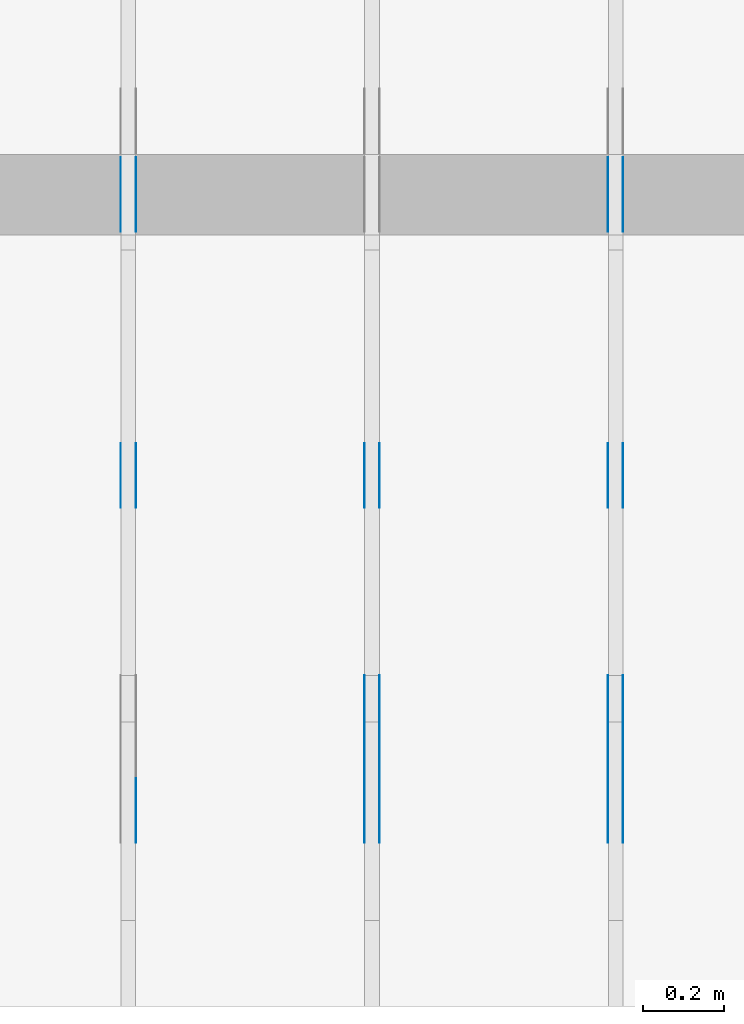
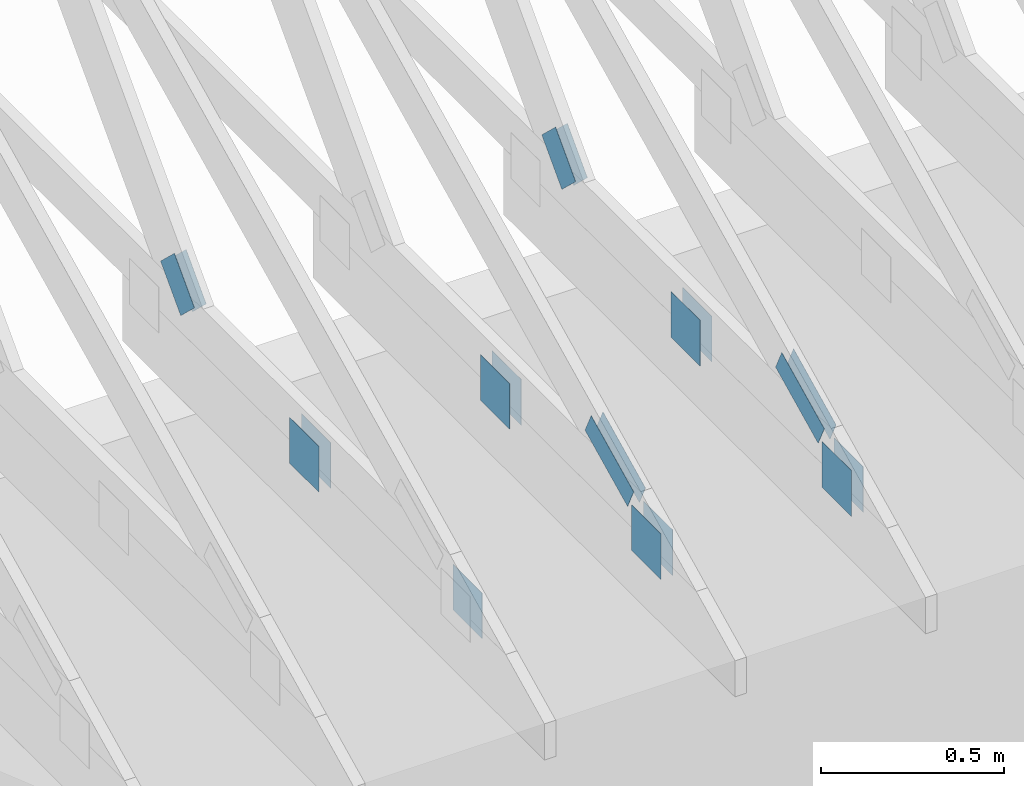
# One storey, part 73 of 159: 19 plates, 3 elements without a shape of their own.
"""IFC2X3 building model written with IfcOpenShell, lengths in millimetres."""

import ifcopenshell
import ifcopenshell.guid

model = None  # the IFC model being written
_history = None  # IfcOwnerHistory: only IFC2X3 demands one
_inside = {}  # id of a spatial element -> (the spatial element, [elements in it])
_under = {}  # id of a project, library or spatial element -> (it, [spatial elements below it])
_declared = {}  # id of a project -> (the project, [libraries it declares])
_typed = {}  # id of a type object -> (the type object, [elements of that type])
_made_of = {}  # id of a material, layer set ... -> (it, [elements and type objects made of it])


def new_model(schema):
    """Start an empty IFC model of exactly this schema.

    Asked for "IFC4X3", IfcOpenShell would pick the latest addendum, in which some entities
    have other attributes; the version numbers below select the first issue.
    IFC2X3 requires an IfcOwnerHistory on every rooted entity: one is made here for all.
    """
    global model, _history
    if schema == "IFC4X3":
        model = ifcopenshell.file(schema_version=(4, 3, 0, 0))
    else:
        model = ifcopenshell.file(schema=schema)
    _inside.clear()
    _under.clear()
    _declared.clear()
    _typed.clear()
    _made_of.clear()
    _history = None
    if model.schema == "IFC2X3":
        org = make("IfcOrganization", Name="unknown")
        user = make(
            "IfcPersonAndOrganization",
            ThePerson=make("IfcPerson", FamilyName="unknown"),
            TheOrganization=org,
        )
        app = make(
            "IfcApplication",
            ApplicationDeveloper=org,
            Version="unknown",
            ApplicationFullName="unknown",
            ApplicationIdentifier="unknown",
        )
        _history = make(
            "IfcOwnerHistory",
            OwningUser=user,
            OwningApplication=app,
            ChangeAction="ADDED",
            CreationDate=0,
        )
    return model


def make(cls, **values):
    """One entity of the class cls with the attributes given. An attribute that is None is left unset."""
    return model.create_entity(
        cls, **{name: value for name, value in values.items() if value is not None}
    )


def rooted(cls, **values):
    """An entity with a GlobalId (a new one), such as an element, a storey or a relation."""
    return make(cls, GlobalId=ifcopenshell.guid.new(), OwnerHistory=_history, **values)


def si_unit(unit_type, name, prefix=None):
    """IfcSIUnit, for example si_unit("LENGTHUNIT", "METRE", prefix="MILLI")."""
    return make("IfcSIUnit", UnitType=unit_type, Prefix=prefix, Name=name)


def assignment(units):
    """IfcUnitAssignment: the units of a project."""
    return None if units is None else make("IfcUnitAssignment", Units=units)


def point(xyz):
    """IfcCartesianPoint."""
    return None if xyz is None else make("IfcCartesianPoint", Coordinates=xyz)


def direction(xyz):
    """IfcDirection."""
    return None if xyz is None else make("IfcDirection", DirectionRatios=xyz)


def frame(location, z_axis=None, x_axis=None):
    """IfcAxis2Placement3D, a coordinate frame: its origin and axes. An axis left out is left unset."""
    return make(
        "IfcAxis2Placement3D",
        Location=point(location),
        Axis=direction(z_axis),
        RefDirection=direction(x_axis),
    )


def frame_2d(location, x_axis=None):
    """IfcAxis2Placement2D, a coordinate frame in the plane: its origin and x axis."""
    return make(
        "IfcAxis2Placement2D", Location=point(location), RefDirection=direction(x_axis)
    )


def origin():
    """The frame at (0, 0, 0) with its axes left unset."""
    return frame((0.0, 0.0, 0.0))


def origin_with_axes():
    """The frame at (0, 0, 0) with the z axis (0, 0, 1) and the x axis (1, 0, 0) written out."""
    return frame((0.0, 0.0, 0.0), z_axis=(0.0, 0.0, 1.0), x_axis=(1.0, 0.0, 0.0))


def origin_2d():
    """The frame at (0, 0) in the plane with its x axis left unset."""
    return frame_2d((0.0, 0.0))


def place(relative_to, where):
    """IfcLocalPlacement: puts the frame where relative to a parent placement (None: the world)."""
    return make(
        "IfcLocalPlacement", PlacementRelTo=relative_to, RelativePlacement=where
    )


def context(
    kind, dimensions, precision=None, world=None, true_north=None, identifier=None
):
    """IfcGeometricRepresentationContext, for example the 3D "Model" context."""
    return make(
        "IfcGeometricRepresentationContext",
        ContextIdentifier=identifier,
        ContextType=kind,
        CoordinateSpaceDimension=dimensions,
        Precision=precision,
        WorldCoordinateSystem=world,
        TrueNorth=true_north,
    )


def project(units=None, contexts=None):
    """IfcProject with its units and contexts."""
    return rooted(
        "IfcProject",
        Name="project",
        RepresentationContexts=contexts,
        UnitsInContext=assignment(units),
    )


def spatial(cls, under=None, at=None, **own):
    """A site, building, storey or space (cls), placed at a placement, below another one or the project."""
    s = rooted(cls, ObjectPlacement=at, **own)
    if under is not None:
        _under.setdefault(under.id(), (under, []))[1].append(s)
    return s


def faces_of(points, faces, orient=None, outer=None):
    """IfcFace entities. A face is a list of loops; a loop is a list of indices into points, from 0.

    orient and outer hold one flag for each loop. By default every Orientation is true, the
    first loop of a face is its IfcFaceOuterBound and the others are IfcFaceBound.
    """
    made = []
    for i, loops in enumerate(faces):
        bounds = []
        for j, loop in enumerate(loops):
            is_outer = j == 0 if outer is None else outer[i][j]
            bounds.append(
                make(
                    "IfcFaceOuterBound" if is_outer else "IfcFaceBound",
                    Bound=make("IfcPolyLoop", Polygon=[points[k] for k in loop]),
                    Orientation=True if orient is None else orient[i][j],
                )
            )
        made.append(make("IfcFace", Bounds=bounds))
    return made


def faceted_brep(points, faces, orient=None, outer=None, voids=None):
    """IfcFacetedBrep: a solid bounded by flat faces; with voids (closed shells), ...WithVoids."""
    shared = [point(p) for p in points]
    hull = make("IfcClosedShell", CfsFaces=faces_of(shared, faces, orient, outer))
    if voids is None:
        return make("IfcFacetedBrep", Outer=hull)
    return make(
        "IfcFacetedBrepWithVoids",
        Outer=hull,
        Voids=[
            make(cls, CfsFaces=faces_of(shared, fs, o, b)) for cls, fs, o, b in voids
        ],
    )


def shape(context_of_items, identifier, shape_type, items):
    """IfcShapeRepresentation: the items that make up one representation, for example the "Body"."""
    return make(
        "IfcShapeRepresentation",
        ContextOfItems=context_of_items,
        RepresentationIdentifier=identifier,
        RepresentationType=shape_type,
        Items=items,
    )


def made_of(thing, what):
    """Note that an element or type object is made of a material, layer set ...; save() writes the relation."""
    if what is not None:
        _made_of.setdefault(what.id(), (what, []))[1].append(thing)
    return thing


def element(
    cls,
    number,
    at=None,
    inside=None,
    cuts=None,
    type_object=None,
    material=None,
    context=None,
    identifier="Body",
    shape_type=None,
    held_by="IfcProductDefinitionShape",
    body=None,
    shapes=None,
    **own,
):
    """One element of the class cls, such as IfcWall. Its Tag is "e" and its number.

    at: its placement. inside: the storey or other place that contains it. cuts: it is an
    opening in that element (IfcRelVoidsElement). A single representation is given by context,
    identifier, shape_type and body (its items); several are given by shapes. held_by: the class
    of the entity that holds the representations. save() writes the other relations.
    """
    e = rooted(cls, Tag="e%d" % number, ObjectPlacement=at, **own)
    if body is not None:
        shapes = [shape(context, identifier, shape_type, body)]
    if shapes is not None:
        e.Representation = make(held_by, Representations=shapes)
    if inside is not None:
        _inside.setdefault(inside.id(), (inside, []))[1].append(e)
    if cuts is not None:
        rooted(
            "IfcRelVoidsElement", RelatingBuildingElement=cuts, RelatedOpeningElement=e
        )
    if type_object is not None:
        _typed.setdefault(type_object.id(), (type_object, []))[1].append(e)
    return made_of(e, material)


def aggregate(whole, parts):
    """IfcRelAggregates: a whole, such as a stair, and the parts it consists of."""
    return rooted("IfcRelAggregates", RelatingObject=whole, RelatedObjects=parts)


def save(model, path):
    """Write the relations noted so far, then the file.

    IfcRelAggregates (storeys below a building ...), IfcRelContainedInSpatialStructure (elements
    in a storey), IfcRelDefinesByType, IfcRelAssociatesMaterial and IfcRelDeclares: one each for
    every whole, place, type object, material and project.
    """
    for whole, parts in _under.values():
        aggregate(whole, parts)
    for where, things in _inside.values():
        rooted(
            "IfcRelContainedInSpatialStructure",
            RelatedElements=things,
            RelatingStructure=where,
        )
    for kind, things in _typed.values():
        rooted("IfcRelDefinesByType", RelatedObjects=things, RelatingType=kind)
    for what, things in _made_of.values():
        rooted("IfcRelAssociatesMaterial", RelatedObjects=things, RelatingMaterial=what)
    for by, libraries in _declared.values():
        rooted("IfcRelDeclares", RelatingContext=by, RelatedDefinitions=libraries)
    model.write(path)


model = new_model("IFC2X3")

# Units and contexts
model_context = context("Model", 3, precision=1e-05, world=origin())
plan_context = context("Plan", 2, precision=1e-05, world=origin_2d())
ifc_project = project(units=[si_unit("LENGTHUNIT", "METRE", prefix="MILLI"), si_unit("AREAUNIT", "SQUARE_METRE"), si_unit("VOLUMEUNIT", "CUBIC_METRE"), si_unit("SOLIDANGLEUNIT", "STERADIAN"), si_unit("PLANEANGLEUNIT", "RADIAN"), si_unit("MASSUNIT", "GRAM"), si_unit("TIMEUNIT", "SECOND"), si_unit("THERMODYNAMICTEMPERATUREUNIT", "DEGREE_CELSIUS"), si_unit("LUMINOUSINTENSITYUNIT", "LUMEN")], contexts=[model_context, plan_context])

# Site, building, storey
site_placement = place(None, origin_with_axes())
site = spatial("IfcSite", under=ifc_project, at=site_placement, CompositionType="ELEMENT")
building_placement = place(site_placement, origin_with_axes())
building = spatial("IfcBuilding", under=site, at=building_placement, Name="Plan 1", CompositionType="ELEMENT")
storey_placement = place(building_placement, origin_with_axes())
storey = spatial("IfcBuildingStorey", under=building, at=storey_placement, Name="Etasje 1", CompositionType="ELEMENT", Elevation=0.0)

# Assembly, plates
assembly_1_placement = place(storey_placement, frame((9075.022261404752, 9699.99999999999, 1.1021457184401395e-15), z_axis=(-1.0, 1.836909530733566e-16, 6.123031769111886e-17), x_axis=(-1.836909530733566e-16, -1.0, 0.0)))
assembly_1 = element("IfcElementAssembly", 1, at=assembly_1_placement, inside=storey, Name="T2 (93)", AssemblyPlace="FACTORY", PredefinedType="TRUSS")
plate_1_placement = place(assembly_1_placement, frame((9849.1689453125, 348.6043090820308, 0.0), z_axis=(0.0, 0.0, 1.0), x_axis=(-0.898794046299167, 0.4383711467890773, 0.0)))
plate_1 = element("IfcPlate", 2, at=plate_1_placement, Name="GNT100S 76x258", context=model_context, shape_type="Brep", body=[
    faceted_brep([(257.99999468874375, 76.00008915613216, 1.0), (0.00017802805450628512, 76.00008915613216, 1.0), (0.0, 0.0, 1.0), (258.0006943892513, 0.0, 1.0), (0.00017802805450628512, 76.00008915613216, 2.1801428670703325e-20), (257.99999468874375, 76.00008915613216, 3.1594843278197516e-14), (258.0006943892513, 0.0003658529813037603, 3.159492896396625e-14), (0.0, 0.0003658529813037603, 0.0), (258.0004204757515, 0.0002198311096505291, -1.1564171119434705e-29), (258.0004204757515, 0.00021983110965059034, 1.0), (0.0004204757515253732, 0.00021983110855223245, 1.0), (0.0004204757515253732, 0.00021983110855217122, -1.8055593228630336e-35), (258.0004204757515, 76.00021983110946, 0.0), (258.0004204757515, 76.00021983110946, 1.0), (258.0004204757515, 0.00021983110946166562, 1.0), (258.0004204757515, 0.00021983110946166562, 0.0), (0.0004204757515253732, 76.00021983110855, 0.0), (0.0004204757515253732, 76.00021983110855, 1.0), (258.0004204757515, 76.00021983110945, 1.0), (258.0004204757515, 76.00021983110945, -7.888609052210118e-31), (0.0004204757515253732, 0.00021983110855217092, -3.009265538105056e-36), (0.00042047575152543446, 0.00021983110855217092, 1.0), (0.00042047575153474146, 76.00021983110855, 1.0), (0.0004204757515346802, 76.00021983110855, -5.698736427475688e-31)], [[[0, 1, 2, 3]], [[4, 5, 6, 7]], [[8, 9, 10, 11]], [[12, 13, 14, 15]], [[16, 17, 18, 19]], [[20, 21, 22, 23]]]),
])
plate_2_placement = place(assembly_1_placement, frame((9849.1689453125, 348.6043090820308, -37.0), z_axis=(0.0, 0.0, 1.0), x_axis=(-0.898794046299167, 0.4383711467890773, 0.0)))
plate_2 = element("IfcPlate", 3, at=plate_2_placement, Name="GNT100S 76x258", context=model_context, shape_type="Brep", body=[
    faceted_brep([(257.99999468874375, 76.00008915613216, 1.0), (0.00017802805450628512, 76.00008915613216, 1.0), (0.0, 0.0, 1.0), (258.0006943892513, 0.0, 1.0), (0.00017802805450628512, 76.00008915613216, 2.1801428670703325e-20), (257.99999468874375, 76.00008915613216, 3.1594843278197516e-14), (258.0006943892513, 0.0003658529813037603, 3.159492896396625e-14), (0.0, 0.0003658529813037603, 0.0), (258.0004204757515, 0.0002198311096505291, -1.1564171119434705e-29), (258.0004204757515, 0.00021983110965059034, 1.0), (0.0004204757515253732, 0.00021983110855223245, 1.0), (0.0004204757515253732, 0.00021983110855217122, -1.8055593228630336e-35), (258.0004204757515, 76.00021983110946, 0.0), (258.0004204757515, 76.00021983110946, 1.0), (258.0004204757515, 0.00021983110946166562, 1.0), (258.0004204757515, 0.00021983110946166562, 0.0), (0.0004204757515253732, 76.00021983110855, 0.0), (0.0004204757515253732, 76.00021983110855, 1.0), (258.0004204757515, 76.00021983110945, 1.0), (258.0004204757515, 76.00021983110945, -7.888609052210118e-31), (0.0004204757515253732, 0.00021983110855217092, -3.009265538105056e-36), (0.00042047575152543446, 0.00021983110855217092, 1.0), (0.00042047575153474146, 76.00021983110855, 1.0), (0.0004204757515346802, 76.00021983110855, -5.698736427475688e-31)], [[[0, 1, 2, 3]], [[4, 5, 6, 7]], [[8, 9, 10, 11]], [[12, 13, 14, 15]], [[16, 17, 18, 19]], [[20, 21, 22, 23]]]),
])
plate_3_placement = place(assembly_1_placement, frame((9172.147647832993, 299.0, 0.0), z_axis=(0.0, 0.0, 1.0), x_axis=(-1.0, 1.2246063538223773e-16, 0.0)))
plate_3 = element("IfcPlate", 4, at=plate_3_placement, Name="GNT100S 152x159", context=model_context, shape_type="Brep", body=[
    faceted_brep([(159.00018689549324, 152.0, 1.0), (0.0001868954932433553, 152.0, 1.0), (0.0001868954932433553, 0.0, 1.0), (159.00018689549324, 0.0, 1.0), (0.0001868954932433553, 152.0, 2.2887340852658008e-20), (159.00018689549324, 152.0, 1.947126391311665e-14), (159.00018689549324, 5.684341886080802e-14, 1.947126391311665e-14), (0.0001868954932433553, 5.684341886080802e-14, 2.2887340852658008e-20), (159.0, 1.4487220288423447e-12, 5.2688860062695115e-30), (159.0, 1.4487832591600358e-12, 1.0), (1.1247455413666031e-32, 1.4779901206986995e-12, 1.0), (0.0, 1.4779288903810084e-12, 0.0), (159.0, 152.0000000000015, 0.0), (159.0, 152.0000000000015, 1.0), (159.0, 1.5347723092418164e-12, 1.0), (159.0, 1.5347723092418164e-12, 0.0), (0.0, 152.00000000000148, 0.0), (0.0, 152.00000000000148, 1.0), (159.0, 152.0000000000015, 1.0), (159.0, 152.0000000000015, 0.0), (1.8098811096582386e-28, 1.4779288903810084e-12, -1.1081959532752868e-44), (6.123031769129986e-17, 1.4779288903810084e-12, 1.0), (1.8675246895791433e-14, 152.00000000000148, 1.0), (1.8614016578100314e-14, 152.00000000000148, -1.1397421485848355e-30)], [[[0, 1, 2, 3]], [[4, 5, 6, 7]], [[8, 9, 10, 11]], [[12, 13, 14, 15]], [[16, 17, 18, 19]], [[20, 21, 22, 23]]]),
])
plate_4_placement = place(assembly_1_placement, frame((9172.147647832993, 299.0, -37.0), z_axis=(0.0, 0.0, 1.0), x_axis=(-1.0, 1.2246063538223773e-16, 0.0)))
plate_4 = element("IfcPlate", 5, at=plate_4_placement, Name="GNT100S 152x159", context=model_context, shape_type="Brep", body=[
    faceted_brep([(159.00018689549324, 152.0, 1.0), (0.0001868954932433553, 152.0, 1.0), (0.0001868954932433553, 0.0, 1.0), (159.00018689549324, 0.0, 1.0), (0.0001868954932433553, 152.0, 2.2887340852658008e-20), (159.00018689549324, 152.0, 1.947126391311665e-14), (159.00018689549324, 5.684341886080802e-14, 1.947126391311665e-14), (0.0001868954932433553, 5.684341886080802e-14, 2.2887340852658008e-20), (159.0, 1.4487220288423447e-12, 5.2688860062695115e-30), (159.0, 1.4487832591600358e-12, 1.0), (1.1247455413666031e-32, 1.4779901206986995e-12, 1.0), (0.0, 1.4779288903810084e-12, 0.0), (159.0, 152.0000000000015, 0.0), (159.0, 152.0000000000015, 1.0), (159.0, 1.5347723092418164e-12, 1.0), (159.0, 1.5347723092418164e-12, 0.0), (0.0, 152.00000000000148, 0.0), (0.0, 152.00000000000148, 1.0), (159.0, 152.0000000000015, 1.0), (159.0, 152.0000000000015, 0.0), (1.8098811096582386e-28, 1.4779288903810084e-12, -1.1081959532752868e-44), (6.123031769129986e-17, 1.4779288903810084e-12, 1.0), (1.8675246895791433e-14, 152.00000000000148, 1.0), (1.8614016578100314e-14, 152.00000000000148, -1.1397421485848355e-30)], [[[0, 1, 2, 3]], [[4, 5, 6, 7]], [[8, 9, 10, 11]], [[12, 13, 14, 15]], [[16, 17, 18, 19]], [[20, 21, 22, 23]]]),
])
plate_5_placement = place(assembly_1_placement, frame((9997.207498348753, 299.0000000000001, 0.0), z_axis=(0.0, 0.0, 1.0), x_axis=(-1.0, 1.2246063538223773e-16, 0.0)))
plate_5 = element("IfcPlate", 6, at=plate_5_placement, Name="GNT100S 152x159", context=model_context, shape_type="Brep", body=[
    faceted_brep([(159.00046709875278, 152.00000000000014, 1.0), (0.0004670987527788384, 152.00000000000014, 1.0), (0.0004670987527788384, 1.1368683772161603e-13, 1.0), (159.00046709875278, 1.1368683772161603e-13, 1.0), (0.0004670987527788384, 152.00000000000014, 5.720121005154733e-20), (159.00046709875278, 152.00000000000014, 1.947129822698585e-14), (159.00046709875278, 1.7053025658242404e-13, 1.947129822698585e-14), (0.0004670987527788384, 1.7053025658242404e-13, 5.720121005154733e-20), (159.0, -2.92068615386637e-14, 5.2688860062695115e-30), (159.0, -2.914563122097258e-14, 1.0), (1.1247455413666031e-32, 6.123031769111886e-17, 1.0), (0.0, 0.0, 0.0), (159.0, 152.00000000000006, 0.0), (159.0, 152.00000000000006, 1.0), (159.0, 5.684341886080802e-14, 1.0), (159.0, 5.684341886080802e-14, 0.0), (0.0, 152.00000000000003, 0.0), (0.0, 152.00000000000003, 1.0), (159.0, 152.00000000000006, 1.0), (159.0, 152.00000000000006, 0.0), (0.0, 0.0, 0.0), (6.123031769111886e-17, -7.498303609110687e-33, 1.0), (1.8675246895791256e-14, 152.00000000000003, 1.0), (1.8614016578100137e-14, 152.00000000000003, -1.1397421485848246e-30)], [[[0, 1, 2, 3]], [[4, 5, 6, 7]], [[8, 9, 10, 11]], [[12, 13, 14, 15]], [[16, 17, 18, 19]], [[20, 21, 22, 23]]]),
])
plate_6_placement = place(assembly_1_placement, frame((9997.207498348753, 299.0000000000001, -37.0), z_axis=(0.0, 0.0, 1.0), x_axis=(-1.0, 1.2246063538223773e-16, 0.0)))
plate_6 = element("IfcPlate", 7, at=plate_6_placement, Name="GNT100S 152x159", context=model_context, shape_type="Brep", body=[
    faceted_brep([(159.00046709875278, 152.00000000000014, 1.0), (0.0004670987527788384, 152.00000000000014, 1.0), (0.0004670987527788384, 1.1368683772161603e-13, 1.0), (159.00046709875278, 1.1368683772161603e-13, 1.0), (0.0004670987527788384, 152.00000000000014, 5.720121005154733e-20), (159.00046709875278, 152.00000000000014, 1.947129822698585e-14), (159.00046709875278, 1.7053025658242404e-13, 1.947129822698585e-14), (0.0004670987527788384, 1.7053025658242404e-13, 5.720121005154733e-20), (159.0, -2.92068615386637e-14, 5.2688860062695115e-30), (159.0, -2.914563122097258e-14, 1.0), (1.1247455413666031e-32, 6.123031769111886e-17, 1.0), (0.0, 0.0, 0.0), (159.0, 152.00000000000006, 0.0), (159.0, 152.00000000000006, 1.0), (159.0, 5.684341886080802e-14, 1.0), (159.0, 5.684341886080802e-14, 0.0), (0.0, 152.00000000000003, 0.0), (0.0, 152.00000000000003, 1.0), (159.0, 152.00000000000006, 1.0), (159.0, 152.00000000000006, 0.0), (0.0, 0.0, 0.0), (6.123031769111886e-17, -7.498303609110687e-33, 1.0), (1.8675246895791256e-14, 152.00000000000003, 1.0), (1.8614016578100137e-14, 152.00000000000003, -1.1397421485848246e-30)], [[[0, 1, 2, 3]], [[4, 5, 6, 7]], [[8, 9, 10, 11]], [[12, 13, 14, 15]], [[16, 17, 18, 19]], [[20, 21, 22, 23]]]),
])
plate_7_placement = place(assembly_1_placement, frame((8493.194053413827, 348.9324838526172, 0.0), z_axis=(0.0, 0.0, 1.0), x_axis=(-0.6895311389452026, 0.724256037893321, 0.0)))
plate_7 = element("IfcPlate", 8, at=plate_7_placement, Name="GNT100S 103x159", context=model_context, shape_type="Brep", body=[
    faceted_brep([(159.0001990814053, 102.99997015670851, 1.0), (0.0, 102.99997015670851, 1.0), (0.0004867198158535757, 0.00049489453977003, 1.0), (159.00001243096904, 0.00049489453977003, 1.0), (0.0, 102.99997015670851, 0.0), (159.0001990814053, 102.99997015670851, 1.9471265405411186e-14), (159.00001243096904, 0.0, 1.9471242548080165e-14), (0.0004867198158535757, 0.0, 5.960401790255462e-20), (159.00019948917543, 0.00018808533965774285, 1.7883478286178417e-30), (159.00019948917543, 0.00018808533965780408, 1.0), (0.00019948917542933486, 0.00018808533968701094, 1.0), (0.00019948917542933486, 0.0001880853396869497, 1.504632769052528e-36), (159.00019948917543, 103.00018808533878, 5.522026336547083e-29), (159.00019948917543, 103.00018808533878, 1.0), (159.00019948917543, 0.00018808533968694974, 1.0), (159.00019948917543, 0.00018808533968694974, 0.0), (0.0001994891754293349, 103.00018808533969, 0.0), (0.0001994891754293349, 103.00018808533969, 1.0), (159.00019948917452, 103.00018808533883, 1.0), (159.00019948917452, 103.00018808533883, 2.3665827156630354e-30), (0.0001994891754293349, 0.00018808533968694974, -1.504632769052528e-36), (0.00019948917542939612, 0.00018808533968694974, 1.0), (0.00019948917544200957, 103.00018808533969, 1.0), (0.00019948917544194834, 103.00018808533969, -7.723264957218936e-31)], [[[0, 1, 2, 3]], [[4, 5, 6, 7]], [[8, 9, 10, 11]], [[12, 13, 14, 15]], [[16, 17, 18, 19]], [[20, 21, 22, 23]]]),
])
plate_8_placement = place(assembly_1_placement, frame((8493.194053413827, 348.9324838526172, -37.0), z_axis=(0.0, 0.0, 1.0), x_axis=(-0.6895311389452026, 0.724256037893321, 0.0)))
plate_8 = element("IfcPlate", 9, at=plate_8_placement, Name="GNT100S 103x159", context=model_context, shape_type="Brep", body=[
    faceted_brep([(159.0001990814053, 102.99997015670851, 1.0), (0.0, 102.99997015670851, 1.0), (0.0004867198158535757, 0.00049489453977003, 1.0), (159.00001243096904, 0.00049489453977003, 1.0), (0.0, 102.99997015670851, 0.0), (159.0001990814053, 102.99997015670851, 1.9471265405411186e-14), (159.00001243096904, 0.0, 1.9471242548080165e-14), (0.0004867198158535757, 0.0, 5.960401790255462e-20), (159.00019948917543, 0.00018808533965774285, 1.7883478286178417e-30), (159.00019948917543, 0.00018808533965780408, 1.0), (0.00019948917542933486, 0.00018808533968701094, 1.0), (0.00019948917542933486, 0.0001880853396869497, 1.504632769052528e-36), (159.00019948917543, 103.00018808533878, 5.522026336547083e-29), (159.00019948917543, 103.00018808533878, 1.0), (159.00019948917543, 0.00018808533968694974, 1.0), (159.00019948917543, 0.00018808533968694974, 0.0), (0.0001994891754293349, 103.00018808533969, 0.0), (0.0001994891754293349, 103.00018808533969, 1.0), (159.00019948917452, 103.00018808533883, 1.0), (159.00019948917452, 103.00018808533883, 2.3665827156630354e-30), (0.0001994891754293349, 0.00018808533968694974, -1.504632769052528e-36), (0.00019948917542939612, 0.00018808533968694974, 1.0), (0.00019948917544200957, 103.00018808533969, 1.0), (0.00019948917544194834, 103.00018808533969, -7.723264957218936e-31)], [[[0, 1, 2, 3]], [[4, 5, 6, 7]], [[8, 9, 10, 11]], [[12, 13, 14, 15]], [[16, 17, 18, 19]], [[20, 21, 22, 23]]]),
])
aggregate(assembly_1, [plate_1, plate_2, plate_3, plate_4, plate_5, plate_6, plate_7, plate_8])

assembly_2_placement = place(storey_placement, frame((8475.022261404752, 9699.99999999999, 1.1021457184401395e-15), z_axis=(-1.0, 1.836909530733566e-16, 6.123031769111886e-17), x_axis=(-1.836909530733566e-16, -1.0, 0.0)))
assembly_2 = element("IfcElementAssembly", 10, at=assembly_2_placement, inside=storey, Name="T2 (92)", AssemblyPlace="FACTORY", PredefinedType="TRUSS")
plate_9_placement = place(assembly_2_placement, frame((9849.1689453125, 348.6043090820308, 0.0), z_axis=(0.0, 0.0, 1.0), x_axis=(-0.898794046299167, 0.4383711467890773, 0.0)))
plate_9 = element("IfcPlate", 11, at=plate_9_placement, Name="GNT100S 76x258", context=model_context, shape_type="Brep", body=[
    faceted_brep([(257.99999468874375, 76.00008915613216, 1.0), (0.00017802805450628512, 76.00008915613216, 1.0), (0.0, 0.0, 1.0), (258.0006943892513, 0.0, 1.0), (0.00017802805450628512, 76.00008915613216, 2.1801428670703325e-20), (257.99999468874375, 76.00008915613216, 3.1594843278197516e-14), (258.0006943892513, 0.0003658529813037603, 3.159492896396625e-14), (0.0, 0.0003658529813037603, 0.0), (258.0004204757515, 0.0002198311096505291, -1.1564171119434705e-29), (258.0004204757515, 0.00021983110965059034, 1.0), (0.0004204757515253732, 0.00021983110855223245, 1.0), (0.0004204757515253732, 0.00021983110855217122, -1.8055593228630336e-35), (258.0004204757515, 76.00021983110946, 0.0), (258.0004204757515, 76.00021983110946, 1.0), (258.0004204757515, 0.00021983110946166562, 1.0), (258.0004204757515, 0.00021983110946166562, 0.0), (0.0004204757515253732, 76.00021983110855, 0.0), (0.0004204757515253732, 76.00021983110855, 1.0), (258.0004204757515, 76.00021983110945, 1.0), (258.0004204757515, 76.00021983110945, -7.888609052210118e-31), (0.0004204757515253732, 0.00021983110855217092, -3.009265538105056e-36), (0.00042047575152543446, 0.00021983110855217092, 1.0), (0.00042047575153474146, 76.00021983110855, 1.0), (0.0004204757515346802, 76.00021983110855, -5.698736427475688e-31)], [[[0, 1, 2, 3]], [[4, 5, 6, 7]], [[8, 9, 10, 11]], [[12, 13, 14, 15]], [[16, 17, 18, 19]], [[20, 21, 22, 23]]]),
])
plate_10_placement = place(assembly_2_placement, frame((9849.1689453125, 348.6043090820308, -37.0), z_axis=(0.0, 0.0, 1.0), x_axis=(-0.898794046299167, 0.4383711467890773, 0.0)))
plate_10 = element("IfcPlate", 12, at=plate_10_placement, Name="GNT100S 76x258", context=model_context, shape_type="Brep", body=[
    faceted_brep([(257.99999468874375, 76.00008915613216, 1.0), (0.00017802805450628512, 76.00008915613216, 1.0), (0.0, 0.0, 1.0), (258.0006943892513, 0.0, 1.0), (0.00017802805450628512, 76.00008915613216, 2.1801428670703325e-20), (257.99999468874375, 76.00008915613216, 3.1594843278197516e-14), (258.0006943892513, 0.0003658529813037603, 3.159492896396625e-14), (0.0, 0.0003658529813037603, 0.0), (258.0004204757515, 0.0002198311096505291, -1.1564171119434705e-29), (258.0004204757515, 0.00021983110965059034, 1.0), (0.0004204757515253732, 0.00021983110855223245, 1.0), (0.0004204757515253732, 0.00021983110855217122, -1.8055593228630336e-35), (258.0004204757515, 76.00021983110946, 0.0), (258.0004204757515, 76.00021983110946, 1.0), (258.0004204757515, 0.00021983110946166562, 1.0), (258.0004204757515, 0.00021983110946166562, 0.0), (0.0004204757515253732, 76.00021983110855, 0.0), (0.0004204757515253732, 76.00021983110855, 1.0), (258.0004204757515, 76.00021983110945, 1.0), (258.0004204757515, 76.00021983110945, -7.888609052210118e-31), (0.0004204757515253732, 0.00021983110855217092, -3.009265538105056e-36), (0.00042047575152543446, 0.00021983110855217092, 1.0), (0.00042047575153474146, 76.00021983110855, 1.0), (0.0004204757515346802, 76.00021983110855, -5.698736427475688e-31)], [[[0, 1, 2, 3]], [[4, 5, 6, 7]], [[8, 9, 10, 11]], [[12, 13, 14, 15]], [[16, 17, 18, 19]], [[20, 21, 22, 23]]]),
])
plate_11_placement = place(assembly_2_placement, frame((9172.147647832993, 299.0, 0.0), z_axis=(0.0, 0.0, 1.0), x_axis=(-1.0, 1.2246063538223773e-16, 0.0)))
plate_11 = element("IfcPlate", 13, at=plate_11_placement, Name="GNT100S 152x159", context=model_context, shape_type="Brep", body=[
    faceted_brep([(159.00018689549324, 152.0, 1.0), (0.0001868954932433553, 152.0, 1.0), (0.0001868954932433553, 0.0, 1.0), (159.00018689549324, 0.0, 1.0), (0.0001868954932433553, 152.0, 2.2887340852658008e-20), (159.00018689549324, 152.0, 1.947126391311665e-14), (159.00018689549324, 5.684341886080802e-14, 1.947126391311665e-14), (0.0001868954932433553, 5.684341886080802e-14, 2.2887340852658008e-20), (159.0, 1.4487220288423447e-12, 5.2688860062695115e-30), (159.0, 1.4487832591600358e-12, 1.0), (1.1247455413666031e-32, 1.4779901206986995e-12, 1.0), (0.0, 1.4779288903810084e-12, 0.0), (159.0, 152.0000000000015, 0.0), (159.0, 152.0000000000015, 1.0), (159.0, 1.5347723092418164e-12, 1.0), (159.0, 1.5347723092418164e-12, 0.0), (0.0, 152.00000000000148, 0.0), (0.0, 152.00000000000148, 1.0), (159.0, 152.0000000000015, 1.0), (159.0, 152.0000000000015, 0.0), (1.8098811096582386e-28, 1.4779288903810084e-12, -1.1081959532752868e-44), (6.123031769129986e-17, 1.4779288903810084e-12, 1.0), (1.8675246895791433e-14, 152.00000000000148, 1.0), (1.8614016578100314e-14, 152.00000000000148, -1.1397421485848355e-30)], [[[0, 1, 2, 3]], [[4, 5, 6, 7]], [[8, 9, 10, 11]], [[12, 13, 14, 15]], [[16, 17, 18, 19]], [[20, 21, 22, 23]]]),
])
plate_12_placement = place(assembly_2_placement, frame((9172.147647832993, 299.0, -37.0), z_axis=(0.0, 0.0, 1.0), x_axis=(-1.0, 1.2246063538223773e-16, 0.0)))
plate_12 = element("IfcPlate", 14, at=plate_12_placement, Name="GNT100S 152x159", context=model_context, shape_type="Brep", body=[
    faceted_brep([(159.00018689549324, 152.0, 1.0), (0.0001868954932433553, 152.0, 1.0), (0.0001868954932433553, 0.0, 1.0), (159.00018689549324, 0.0, 1.0), (0.0001868954932433553, 152.0, 2.2887340852658008e-20), (159.00018689549324, 152.0, 1.947126391311665e-14), (159.00018689549324, 5.684341886080802e-14, 1.947126391311665e-14), (0.0001868954932433553, 5.684341886080802e-14, 2.2887340852658008e-20), (159.0, 1.4487220288423447e-12, 5.2688860062695115e-30), (159.0, 1.4487832591600358e-12, 1.0), (1.1247455413666031e-32, 1.4779901206986995e-12, 1.0), (0.0, 1.4779288903810084e-12, 0.0), (159.0, 152.0000000000015, 0.0), (159.0, 152.0000000000015, 1.0), (159.0, 1.5347723092418164e-12, 1.0), (159.0, 1.5347723092418164e-12, 0.0), (0.0, 152.00000000000148, 0.0), (0.0, 152.00000000000148, 1.0), (159.0, 152.0000000000015, 1.0), (159.0, 152.0000000000015, 0.0), (1.8098811096582386e-28, 1.4779288903810084e-12, -1.1081959532752868e-44), (6.123031769129986e-17, 1.4779288903810084e-12, 1.0), (1.8675246895791433e-14, 152.00000000000148, 1.0), (1.8614016578100314e-14, 152.00000000000148, -1.1397421485848355e-30)], [[[0, 1, 2, 3]], [[4, 5, 6, 7]], [[8, 9, 10, 11]], [[12, 13, 14, 15]], [[16, 17, 18, 19]], [[20, 21, 22, 23]]]),
])
plate_13_placement = place(assembly_2_placement, frame((9997.207498348753, 299.0000000000001, 0.0), z_axis=(0.0, 0.0, 1.0), x_axis=(-1.0, 1.2246063538223773e-16, 0.0)))
plate_13 = element("IfcPlate", 15, at=plate_13_placement, Name="GNT100S 152x159", context=model_context, shape_type="Brep", body=[
    faceted_brep([(159.00046709875278, 152.00000000000014, 1.0), (0.0004670987527788384, 152.00000000000014, 1.0), (0.0004670987527788384, 1.1368683772161603e-13, 1.0), (159.00046709875278, 1.1368683772161603e-13, 1.0), (0.0004670987527788384, 152.00000000000014, 5.720121005154733e-20), (159.00046709875278, 152.00000000000014, 1.947129822698585e-14), (159.00046709875278, 1.7053025658242404e-13, 1.947129822698585e-14), (0.0004670987527788384, 1.7053025658242404e-13, 5.720121005154733e-20), (159.0, -2.92068615386637e-14, 5.2688860062695115e-30), (159.0, -2.914563122097258e-14, 1.0), (1.1247455413666031e-32, 6.123031769111886e-17, 1.0), (0.0, 0.0, 0.0), (159.0, 152.00000000000006, 0.0), (159.0, 152.00000000000006, 1.0), (159.0, 5.684341886080802e-14, 1.0), (159.0, 5.684341886080802e-14, 0.0), (0.0, 152.00000000000003, 0.0), (0.0, 152.00000000000003, 1.0), (159.0, 152.00000000000006, 1.0), (159.0, 152.00000000000006, 0.0), (0.0, 0.0, 0.0), (6.123031769111886e-17, -7.498303609110687e-33, 1.0), (1.8675246895791256e-14, 152.00000000000003, 1.0), (1.8614016578100137e-14, 152.00000000000003, -1.1397421485848246e-30)], [[[0, 1, 2, 3]], [[4, 5, 6, 7]], [[8, 9, 10, 11]], [[12, 13, 14, 15]], [[16, 17, 18, 19]], [[20, 21, 22, 23]]]),
])
plate_14_placement = place(assembly_2_placement, frame((9997.207498348753, 299.0000000000001, -37.0), z_axis=(0.0, 0.0, 1.0), x_axis=(-1.0, 1.2246063538223773e-16, 0.0)))
plate_14 = element("IfcPlate", 16, at=plate_14_placement, Name="GNT100S 152x159", context=model_context, shape_type="Brep", body=[
    faceted_brep([(159.00046709875278, 152.00000000000014, 1.0), (0.0004670987527788384, 152.00000000000014, 1.0), (0.0004670987527788384, 1.1368683772161603e-13, 1.0), (159.00046709875278, 1.1368683772161603e-13, 1.0), (0.0004670987527788384, 152.00000000000014, 5.720121005154733e-20), (159.00046709875278, 152.00000000000014, 1.947129822698585e-14), (159.00046709875278, 1.7053025658242404e-13, 1.947129822698585e-14), (0.0004670987527788384, 1.7053025658242404e-13, 5.720121005154733e-20), (159.0, -2.92068615386637e-14, 5.2688860062695115e-30), (159.0, -2.914563122097258e-14, 1.0), (1.1247455413666031e-32, 6.123031769111886e-17, 1.0), (0.0, 0.0, 0.0), (159.0, 152.00000000000006, 0.0), (159.0, 152.00000000000006, 1.0), (159.0, 5.684341886080802e-14, 1.0), (159.0, 5.684341886080802e-14, 0.0), (0.0, 152.00000000000003, 0.0), (0.0, 152.00000000000003, 1.0), (159.0, 152.00000000000006, 1.0), (159.0, 152.00000000000006, 0.0), (0.0, 0.0, 0.0), (6.123031769111886e-17, -7.498303609110687e-33, 1.0), (1.8675246895791256e-14, 152.00000000000003, 1.0), (1.8614016578100137e-14, 152.00000000000003, -1.1397421485848246e-30)], [[[0, 1, 2, 3]], [[4, 5, 6, 7]], [[8, 9, 10, 11]], [[12, 13, 14, 15]], [[16, 17, 18, 19]], [[20, 21, 22, 23]]]),
])
aggregate(assembly_2, [plate_9, plate_10, plate_11, plate_12, plate_13, plate_14])

assembly_3_placement = place(storey_placement, frame((7875.0222614047525, 9699.99999999999, 1.1021457184401395e-15), z_axis=(-1.0, 1.836909530733566e-16, 6.123031769111886e-17), x_axis=(-1.836909530733566e-16, -1.0, 0.0)))
assembly_3 = element("IfcElementAssembly", 17, at=assembly_3_placement, inside=storey, Name="T2 (91)", AssemblyPlace="FACTORY", PredefinedType="TRUSS")
plate_15_placement = place(assembly_3_placement, frame((9172.147647832993, 299.0, 0.0), z_axis=(0.0, 0.0, 1.0), x_axis=(-1.0, 1.2246063538223773e-16, 0.0)))
plate_15 = element("IfcPlate", 18, at=plate_15_placement, Name="GNT100S 152x159", context=model_context, shape_type="Brep", body=[
    faceted_brep([(159.00018689549324, 152.0, 1.0), (0.0001868954932433553, 152.0, 1.0), (0.0001868954932433553, 0.0, 1.0), (159.00018689549324, 0.0, 1.0), (0.0001868954932433553, 152.0, 2.2887340852658008e-20), (159.00018689549324, 152.0, 1.947126391311665e-14), (159.00018689549324, 5.684341886080802e-14, 1.947126391311665e-14), (0.0001868954932433553, 5.684341886080802e-14, 2.2887340852658008e-20), (159.0, 1.4487220288423447e-12, 5.2688860062695115e-30), (159.0, 1.4487832591600358e-12, 1.0), (1.1247455413666031e-32, 1.4779901206986995e-12, 1.0), (0.0, 1.4779288903810084e-12, 0.0), (159.0, 152.0000000000015, 0.0), (159.0, 152.0000000000015, 1.0), (159.0, 1.5347723092418164e-12, 1.0), (159.0, 1.5347723092418164e-12, 0.0), (0.0, 152.00000000000148, 0.0), (0.0, 152.00000000000148, 1.0), (159.0, 152.0000000000015, 1.0), (159.0, 152.0000000000015, 0.0), (1.8098811096582386e-28, 1.4779288903810084e-12, -1.1081959532752868e-44), (6.123031769129986e-17, 1.4779288903810084e-12, 1.0), (1.8675246895791433e-14, 152.00000000000148, 1.0), (1.8614016578100314e-14, 152.00000000000148, -1.1397421485848355e-30)], [[[0, 1, 2, 3]], [[4, 5, 6, 7]], [[8, 9, 10, 11]], [[12, 13, 14, 15]], [[16, 17, 18, 19]], [[20, 21, 22, 23]]]),
])
plate_16_placement = place(assembly_3_placement, frame((9172.147647832993, 299.0, -37.0), z_axis=(0.0, 0.0, 1.0), x_axis=(-1.0, 1.2246063538223773e-16, 0.0)))
plate_16 = element("IfcPlate", 19, at=plate_16_placement, Name="GNT100S 152x159", context=model_context, shape_type="Brep", body=[
    faceted_brep([(159.00018689549324, 152.0, 1.0), (0.0001868954932433553, 152.0, 1.0), (0.0001868954932433553, 0.0, 1.0), (159.00018689549324, 0.0, 1.0), (0.0001868954932433553, 152.0, 2.2887340852658008e-20), (159.00018689549324, 152.0, 1.947126391311665e-14), (159.00018689549324, 5.684341886080802e-14, 1.947126391311665e-14), (0.0001868954932433553, 5.684341886080802e-14, 2.2887340852658008e-20), (159.0, 1.4487220288423447e-12, 5.2688860062695115e-30), (159.0, 1.4487832591600358e-12, 1.0), (1.1247455413666031e-32, 1.4779901206986995e-12, 1.0), (0.0, 1.4779288903810084e-12, 0.0), (159.0, 152.0000000000015, 0.0), (159.0, 152.0000000000015, 1.0), (159.0, 1.5347723092418164e-12, 1.0), (159.0, 1.5347723092418164e-12, 0.0), (0.0, 152.00000000000148, 0.0), (0.0, 152.00000000000148, 1.0), (159.0, 152.0000000000015, 1.0), (159.0, 152.0000000000015, 0.0), (1.8098811096582386e-28, 1.4779288903810084e-12, -1.1081959532752868e-44), (6.123031769129986e-17, 1.4779288903810084e-12, 1.0), (1.8675246895791433e-14, 152.00000000000148, 1.0), (1.8614016578100314e-14, 152.00000000000148, -1.1397421485848355e-30)], [[[0, 1, 2, 3]], [[4, 5, 6, 7]], [[8, 9, 10, 11]], [[12, 13, 14, 15]], [[16, 17, 18, 19]], [[20, 21, 22, 23]]]),
])
plate_17_placement = place(assembly_3_placement, frame((9997.207498348753, 299.0000000000001, -37.0), z_axis=(0.0, 0.0, 1.0), x_axis=(-1.0, 1.2246063538223773e-16, 0.0)))
plate_17 = element("IfcPlate", 20, at=plate_17_placement, Name="GNT100S 152x159", context=model_context, shape_type="Brep", body=[
    faceted_brep([(159.00046709875278, 152.00000000000014, 1.0), (0.0004670987527788384, 152.00000000000014, 1.0), (0.0004670987527788384, 1.1368683772161603e-13, 1.0), (159.00046709875278, 1.1368683772161603e-13, 1.0), (0.0004670987527788384, 152.00000000000014, 5.720121005154733e-20), (159.00046709875278, 152.00000000000014, 1.947129822698585e-14), (159.00046709875278, 1.7053025658242404e-13, 1.947129822698585e-14), (0.0004670987527788384, 1.7053025658242404e-13, 5.720121005154733e-20), (159.0, -2.92068615386637e-14, 5.2688860062695115e-30), (159.0, -2.914563122097258e-14, 1.0), (1.1247455413666031e-32, 6.123031769111886e-17, 1.0), (0.0, 0.0, 0.0), (159.0, 152.00000000000006, 0.0), (159.0, 152.00000000000006, 1.0), (159.0, 5.684341886080802e-14, 1.0), (159.0, 5.684341886080802e-14, 0.0), (0.0, 152.00000000000003, 0.0), (0.0, 152.00000000000003, 1.0), (159.0, 152.00000000000006, 1.0), (159.0, 152.00000000000006, 0.0), (0.0, 0.0, 0.0), (6.123031769111886e-17, -7.498303609110687e-33, 1.0), (1.8675246895791256e-14, 152.00000000000003, 1.0), (1.8614016578100137e-14, 152.00000000000003, -1.1397421485848246e-30)], [[[0, 1, 2, 3]], [[4, 5, 6, 7]], [[8, 9, 10, 11]], [[12, 13, 14, 15]], [[16, 17, 18, 19]], [[20, 21, 22, 23]]]),
])
plate_18_placement = place(assembly_3_placement, frame((8493.194053413827, 348.9324838526172, 0.0), z_axis=(0.0, 0.0, 1.0), x_axis=(-0.6895311389452026, 0.724256037893321, 0.0)))
plate_18 = element("IfcPlate", 21, at=plate_18_placement, Name="GNT100S 103x159", context=model_context, shape_type="Brep", body=[
    faceted_brep([(159.0001990814053, 102.99997015670851, 1.0), (0.0, 102.99997015670851, 1.0), (0.0004867198158535757, 0.00049489453977003, 1.0), (159.00001243096904, 0.00049489453977003, 1.0), (0.0, 102.99997015670851, 0.0), (159.0001990814053, 102.99997015670851, 1.9471265405411186e-14), (159.00001243096904, 0.0, 1.9471242548080165e-14), (0.0004867198158535757, 0.0, 5.960401790255462e-20), (159.00019948917543, 0.00018808533965774285, 1.7883478286178417e-30), (159.00019948917543, 0.00018808533965780408, 1.0), (0.00019948917542933486, 0.00018808533968701094, 1.0), (0.00019948917542933486, 0.0001880853396869497, 1.504632769052528e-36), (159.00019948917543, 103.00018808533878, 5.522026336547083e-29), (159.00019948917543, 103.00018808533878, 1.0), (159.00019948917543, 0.00018808533968694974, 1.0), (159.00019948917543, 0.00018808533968694974, 0.0), (0.0001994891754293349, 103.00018808533969, 0.0), (0.0001994891754293349, 103.00018808533969, 1.0), (159.00019948917452, 103.00018808533883, 1.0), (159.00019948917452, 103.00018808533883, 2.3665827156630354e-30), (0.0001994891754293349, 0.00018808533968694974, -1.504632769052528e-36), (0.00019948917542939612, 0.00018808533968694974, 1.0), (0.00019948917544200957, 103.00018808533969, 1.0), (0.00019948917544194834, 103.00018808533969, -7.723264957218936e-31)], [[[0, 1, 2, 3]], [[4, 5, 6, 7]], [[8, 9, 10, 11]], [[12, 13, 14, 15]], [[16, 17, 18, 19]], [[20, 21, 22, 23]]]),
])
plate_19_placement = place(assembly_3_placement, frame((8493.194053413827, 348.9324838526172, -37.0), z_axis=(0.0, 0.0, 1.0), x_axis=(-0.6895311389452026, 0.724256037893321, 0.0)))
plate_19 = element("IfcPlate", 22, at=plate_19_placement, Name="GNT100S 103x159", context=model_context, shape_type="Brep", body=[
    faceted_brep([(159.0001990814053, 102.99997015670851, 1.0), (0.0, 102.99997015670851, 1.0), (0.0004867198158535757, 0.00049489453977003, 1.0), (159.00001243096904, 0.00049489453977003, 1.0), (0.0, 102.99997015670851, 0.0), (159.0001990814053, 102.99997015670851, 1.9471265405411186e-14), (159.00001243096904, 0.0, 1.9471242548080165e-14), (0.0004867198158535757, 0.0, 5.960401790255462e-20), (159.00019948917543, 0.00018808533965774285, 1.7883478286178417e-30), (159.00019948917543, 0.00018808533965780408, 1.0), (0.00019948917542933486, 0.00018808533968701094, 1.0), (0.00019948917542933486, 0.0001880853396869497, 1.504632769052528e-36), (159.00019948917543, 103.00018808533878, 5.522026336547083e-29), (159.00019948917543, 103.00018808533878, 1.0), (159.00019948917543, 0.00018808533968694974, 1.0), (159.00019948917543, 0.00018808533968694974, 0.0), (0.0001994891754293349, 103.00018808533969, 0.0), (0.0001994891754293349, 103.00018808533969, 1.0), (159.00019948917452, 103.00018808533883, 1.0), (159.00019948917452, 103.00018808533883, 2.3665827156630354e-30), (0.0001994891754293349, 0.00018808533968694974, -1.504632769052528e-36), (0.00019948917542939612, 0.00018808533968694974, 1.0), (0.00019948917544200957, 103.00018808533969, 1.0), (0.00019948917544194834, 103.00018808533969, -7.723264957218936e-31)], [[[0, 1, 2, 3]], [[4, 5, 6, 7]], [[8, 9, 10, 11]], [[12, 13, 14, 15]], [[16, 17, 18, 19]], [[20, 21, 22, 23]]]),
])
aggregate(assembly_3, [plate_15, plate_16, plate_17, plate_18, plate_19])

save(model, "model.ifc")
